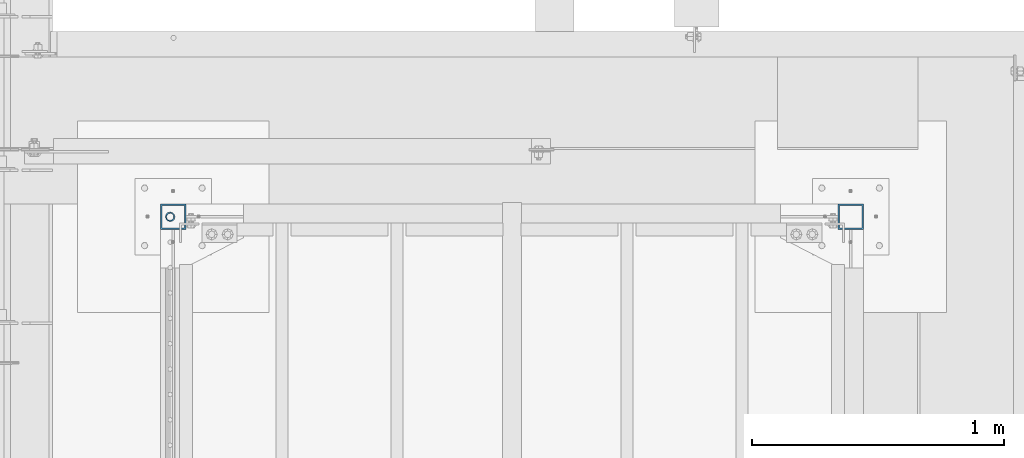
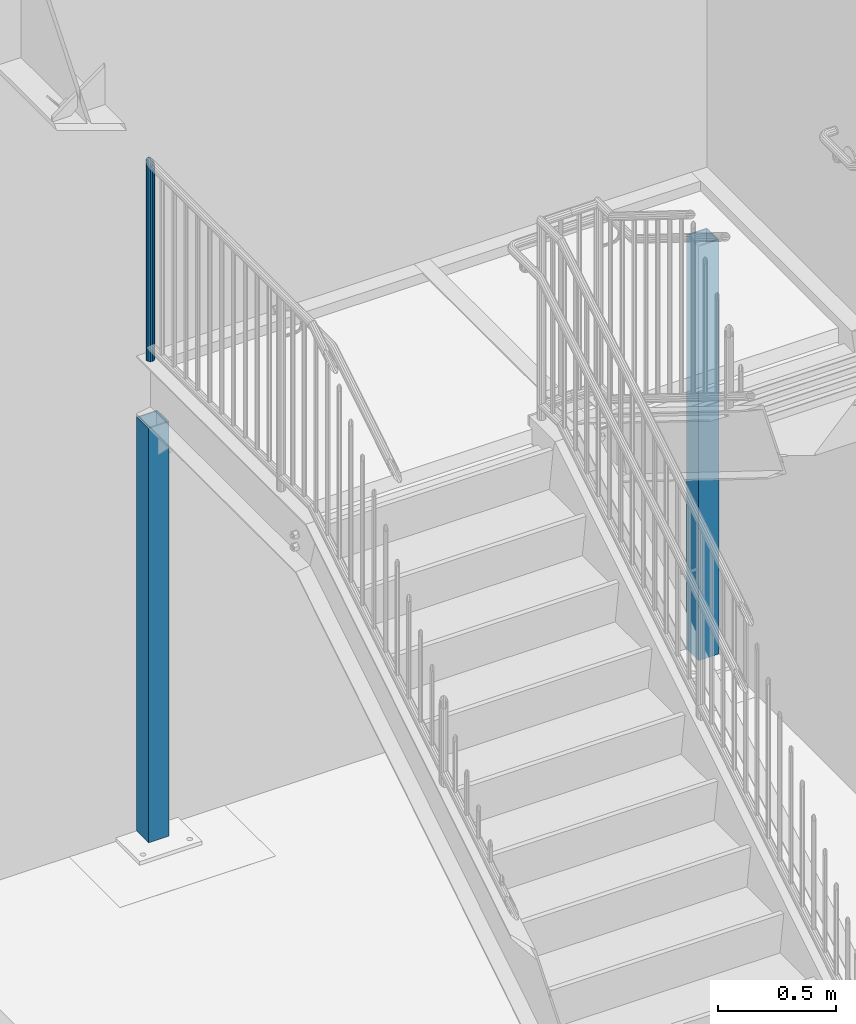
# One storey, part 906 of 1763: 3 columns, 3 elements without a shape of their own.
"""IFC2X3 building model written with IfcOpenShell, lengths in millimetres."""

from ifc_helpers import new_model, si_unit, frame, origin_with_axes, place, context, subcontext, project, spatial, faceted_brep, material, type_object, element, aggregate, save


model = new_model("IFC2X3")

# Units and contexts
model_context = context("Model", 3, precision=1e-05, world=origin_with_axes())
body_context = subcontext(model_context, "Body", "Model", "MODEL_VIEW")
ifc_project = project(units=[si_unit("LENGTHUNIT", "METRE", prefix="MILLI"), si_unit("AREAUNIT", "SQUARE_METRE"), si_unit("VOLUMEUNIT", "CUBIC_METRE"), si_unit("MASSUNIT", "GRAM", prefix="KILO"), si_unit("TIMEUNIT", "SECOND"), si_unit("PLANEANGLEUNIT", "RADIAN"), si_unit("SOLIDANGLEUNIT", "STERADIAN"), si_unit("THERMODYNAMICTEMPERATUREUNIT", "DEGREE_CELSIUS"), si_unit("LUMINOUSINTENSITYUNIT", "LUMEN")], contexts=[model_context])

# Site, building, storey
site_placement = place(None, origin_with_axes())
site = spatial("IfcSite", under=ifc_project, at=site_placement, CompositionType="ELEMENT")
building_placement = place(site_placement, origin_with_axes())
building = spatial("IfcBuilding", under=site, at=building_placement, Name="Undefined", CompositionType="ELEMENT")
storey_placement = place(building_placement, origin_with_axes())
storey = spatial("IfcBuildingStorey", under=building, at=storey_placement, Name="Undefined", CompositionType="ELEMENT", Elevation=0.0)

# Assembly, column
assembly_1_placement = place(storey_placement, origin_with_axes())
assembly_1 = element("IfcElementAssembly", 1, at=assembly_1_placement, inside=storey, Name="RAIL", AssemblyPlace="NOTDEFINED", PredefinedType="RIGID_FRAME")
ifc_material_1 = material(Name="STEEL/A513")
column_type_1 = type_object("IfcColumnType", PredefinedType="NOTDEFINED")
column_1_placement = place(assembly_1_placement, frame((-86778.5372736932, 37299.9000003693, 2782.8875000151), z_axis=(0.0, -1.0, 0.0), x_axis=(0.0, 0.0, 1.0)))
column_1 = element("IfcColumn", 2, at=column_1_placement, type_object=column_type_1, material=ifc_material_1, Name="POST", context=body_context, shape_type="Brep", body=[
    faceted_brep([(0.0, -14.2875000000058, 0.0), (0.0, -12.3733379565674, 7.14374999999927), (1008.85624997355, -12.3733379565674, 7.14375000000291), (1015.99999997355, -14.2875000000058, 0.0), (0.0, -7.14375000000291, 12.373337956571), (1003.62666201698, -7.14375000000291, 12.3733379565674), (0.0, 0.0, 14.2874999999985), (1001.71249997355, 0.0, 14.2874999999985), (0.0, 7.14375000000291, 12.373337956571), (1003.62666201698, 7.14375000000291, 12.3733379565674), (0.0, 12.3733379565674, 7.14374999999927), (1008.85624997355, 12.3733379565674, 7.14375000000291), (0.0, 14.2875000000058, 0.0), (1015.99999997355, 14.2875000000058, 0.0), (0.0, 12.3733379565674, -7.14374999999927), (1023.14374997355, 12.3733379565674, -7.14375000000291), (0.0, 7.14375000000291, -12.373337956571), (1028.37333793012, 7.14375000000291, -12.3733379565674), (0.0, 0.0, -14.2874999999985), (1030.28749997355, 0.0, -14.2874999999985), (0.0, -7.14375000000291, -12.373337956571), (1028.37333793012, -7.14375000000291, -12.3733379565674), (0.0, -12.3733379565674, -7.14374999999927), (1023.14374997355, -12.3733379565674, -7.14375000000291), (0.0, -19.0500000000029, 0.0), (0.0, -16.4977839420899, -9.52500000000146), (1025.52499997355, -16.4977839420899, -9.52500000000146), (1015.99999997355, -19.0500000000029, 0.0), (0.0, -9.52499999999418, -16.4977839420935), (1032.49778391565, -9.52499999999418, -16.4977839420972), (1.45519152283669e-11, 1.81898940354586e-12, -19.0499999999993), (1035.04999997355, 0.0, -19.0500000000029), (0.0, 9.52499999999418, -16.4977839420935), (1032.49778391565, 9.52499999999418, -16.4977839420972), (0.0, 16.4977839420899, -9.52500000000146), (1025.52499997355, 16.4977839420899, -9.52500000000146), (0.0, 19.0500000000029, 0.0), (1015.99999997355, 19.0500000000029, 0.0), (0.0, 16.4977839420899, 9.52500000000146), (1006.47499997355, 16.4977839420899, 9.52500000000146), (0.0, 9.52499999999418, 16.4977839420935), (999.50221603146, 9.52499999999418, 16.4977839420972), (1.45519152283669e-11, 1.81898940354586e-12, 19.0499999999993), (996.949999973554, 0.0, 19.0500000000029), (0.0, -9.52499999999418, 16.4977839420935), (999.50221603146, -9.52499999999418, 16.4977839420972), (0.0, -16.4977839420899, 9.52500000000146), (1006.47499997355, -16.4977839420899, 9.52500000000146)], [[[0, 1, 2, 3]], [[1, 4, 5, 2]], [[4, 6, 7, 5]], [[6, 8, 9, 7]], [[8, 10, 11, 9]], [[10, 12, 13, 11]], [[12, 14, 15, 13]], [[14, 16, 17, 15]], [[16, 18, 19, 17]], [[18, 20, 21, 19]], [[20, 22, 23, 21]], [[22, 0, 3, 23]], [[24, 25, 26, 27]], [[25, 28, 29, 26]], [[28, 30, 31, 29]], [[30, 32, 33, 31]], [[32, 34, 35, 33]], [[34, 36, 37, 35]], [[36, 38, 39, 37]], [[38, 40, 41, 39]], [[40, 42, 43, 41]], [[42, 44, 45, 43]], [[44, 46, 47, 45]], [[46, 24, 27, 47]], [[29, 31, 33, 35, 37, 39, 41, 43, 45, 47, 27, 26], [5, 7, 9, 11, 13, 15, 17, 19, 21, 23, 3, 2]], [[46, 44, 42, 40, 38, 36, 34, 32, 30, 28, 25, 24], [22, 20, 18, 16, 14, 12, 10, 8, 6, 4, 1, 0]]]),
])
aggregate(assembly_1, [column_1])

assembly_2_placement = place(storey_placement, origin_with_axes())
assembly_2 = element("IfcElementAssembly", 3, at=assembly_2_placement, inside=storey, Name="COLUMN", AssemblyPlace="NOTDEFINED", PredefinedType="RIGID_FRAME")
ifc_material_2 = material()
column_type_2 = type_object("IfcColumnType", Name="HSS4X4X1/4", PredefinedType="NOTDEFINED")
column_2_placement = place(assembly_2_placement, frame((-86765.8372736874, 37299.9, 304.80000000001), z_axis=(0.0, 1.0, 0.0), x_axis=(0.0, 0.0, 1.0)))
column_2 = element("IfcColumn", 4, at=column_2_placement, type_object=column_type_2, material=ifc_material_2, Name="COLUMN", ObjectType="HSS4X4X1/4", context=body_context, shape_type="Brep", body=[
    faceted_brep([(19.0500000000045, 44.4499999999971, -44.4499999999971), (19.0500000000045, -44.4499999999971, -44.4499999999971), (2163.7625, -44.4499999999971, -44.4499999999971), (2163.7625, 44.4499999999971, -44.4499999999971), (19.0500000000045, -44.4499999999971, 44.4499999999971), (2163.7625, -44.4499999999971, 44.4499999999971), (19.0500000000045, 44.4499999999971, 44.4499999999971), (2163.7625, 44.4499999999971, 44.4499999999971), (19.0500000000045, 50.8000000000029, -50.8000000000029), (19.0500000000045, 50.8000000000029, 50.8000000000029), (2163.7625, 50.8000000000029, 50.8000000000029), (2163.7625, 50.8000000000029, -50.8000000000029), (19.0500000000045, -50.8000000000029, 50.8000000000029), (2163.7625, -50.8000000000029, 50.8000000000029), (19.0500000000045, -50.8000000000029, -50.8000000000029), (2163.7625, -50.8000000000029, -50.8000000000029)], [[[0, 1, 2, 3]], [[1, 4, 5, 2]], [[4, 6, 7, 5]], [[6, 0, 3, 7]], [[8, 9, 10, 11]], [[9, 12, 13, 10]], [[12, 14, 15, 13]], [[14, 8, 11, 15]], [[13, 15, 11, 10], [5, 7, 3, 2]], [[14, 12, 9, 8], [6, 4, 1, 0]]]),
])
aggregate(assembly_2, [column_2])

assembly_3_placement = place(storey_placement, origin_with_axes())
assembly_3 = element("IfcElementAssembly", 5, at=assembly_3_placement, inside=storey, Name="COLUMN", AssemblyPlace="NOTDEFINED", PredefinedType="RIGID_FRAME")
column_3_placement = place(assembly_3_placement, frame((-84073.3721013126, 37299.9, 304.800000000007), z_axis=(0.0, 1.0, 0.0), x_axis=(0.0, 0.0, 1.0)))
column_3 = element("IfcColumn", 6, at=column_3_placement, type_object=column_type_2, material=ifc_material_2, Name="COLUMN", ObjectType="HSS4X4X1/4", context=body_context, shape_type="Brep", body=[
    faceted_brep([(19.0500000000045, 44.4499999999971, -44.4499999999971), (19.0500000000045, -44.4499999999971, -44.4499999999971), (2163.7625, -44.4499999999971, -44.4499999999971), (2163.7625, 44.4499999999971, -44.4499999999971), (19.0500000000045, -44.4499999999971, 44.4499999999971), (2163.7625, -44.4499999999971, 44.4499999999971), (19.0500000000045, 44.4499999999971, 44.4499999999971), (2163.7625, 44.4499999999971, 44.4499999999971), (19.0500000000045, 50.8000000000029, -50.8000000000029), (19.0500000000045, 50.8000000000029, 50.8000000000029), (2163.7625, 50.8000000000029, 50.8000000000029), (2163.7625, 50.8000000000029, -50.8000000000029), (19.0500000000045, -50.8000000000029, 50.8000000000029), (2163.7625, -50.8000000000029, 50.8000000000029), (19.0500000000045, -50.8000000000029, -50.8000000000029), (2163.7625, -50.8000000000029, -50.8000000000029)], [[[0, 1, 2, 3]], [[1, 4, 5, 2]], [[4, 6, 7, 5]], [[6, 0, 3, 7]], [[8, 9, 10, 11]], [[9, 12, 13, 10]], [[12, 14, 15, 13]], [[14, 8, 11, 15]], [[13, 15, 11, 10], [5, 7, 3, 2]], [[14, 12, 9, 8], [6, 4, 1, 0]]]),
])
aggregate(assembly_3, [column_3])

save(model, "model.ifc")
